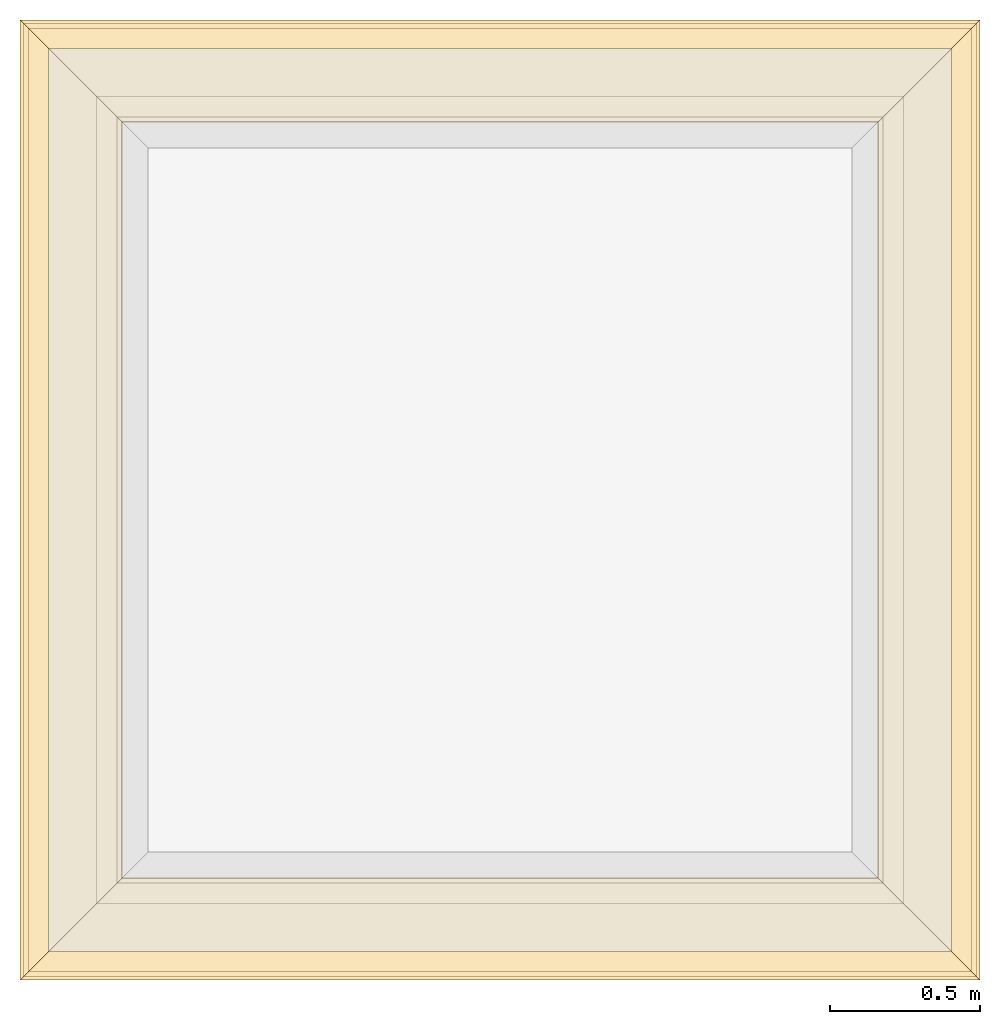
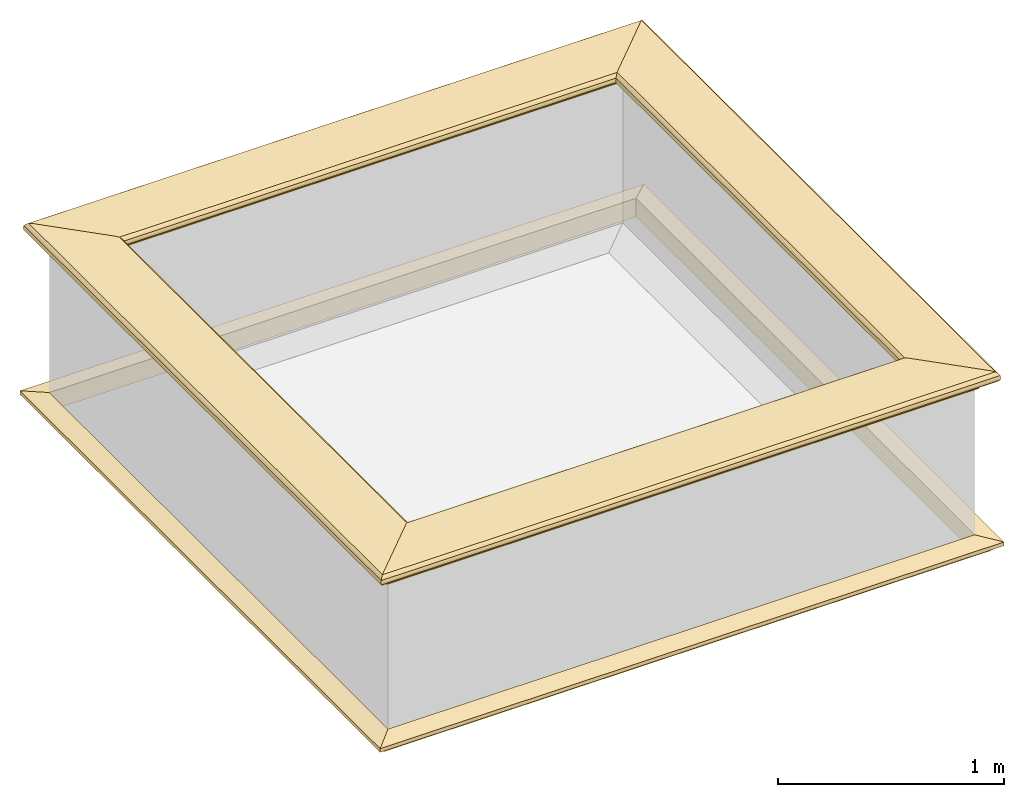
# One storey, part 2 of 2: 8 coverings, 2 elements without a shape of their own.
"""IFC4 building model written with IfcOpenShell, lengths in metres."""

from ifc_helpers import new_model, si_unit, frame, origin_with_axes, origin_2d_with_axis, place, context, subcontext, project, library, spatial, polyline, outline, extrude, clip, halfspace, material, material_profile, profile_set, profile_usage, type_object, element, aggregate, save


model = new_model("IFC4")

# Units and contexts
model_context = context("Model", 3, precision=1e-05, world=origin_with_axes())
plan_context = context("Plan", 2, precision=1e-05, world=origin_2d_with_axis())
body_context = subcontext(model_context, "Body", "Model", "MODEL_VIEW")
ifc_project = project(units=[si_unit("LENGTHUNIT", "METRE"), si_unit("AREAUNIT", "SQUARE_METRE"), si_unit("VOLUMEUNIT", "CUBIC_METRE"), si_unit("PLANEANGLEUNIT", "RADIAN")], contexts=[model_context, plan_context])
project_library = library(declared=ifc_project)

# Site, building, storey
site = spatial("IfcSite", under=ifc_project)
building = spatial("IfcBuilding", under=site, Name="Cube")
storey_placement = place(None, frame((0.0, 0.0, 2.5), z_axis=(0.0, 0.0, 1.0), x_axis=(1.0, 0.0, 0.0)))
storey = spatial("IfcBuildingStorey", under=building, at=storey_placement, Name="1", CompositionType="ELEMENT", Elevation=2.5)

# Assembly, coverings
assembly_1_placement = place(storey_placement, frame((0.0, 0.0, -2.5), z_axis=(0.0, 0.0, 1.0), x_axis=(1.0, 0.0, 0.0)))
assembly_1 = element("IfcElementAssembly", 1, at=assembly_1_placement, inside=storey, Name="coping")
ifc_material = material(Name="Masonry")
ifc_material_profile_1 = material_profile(ifc_material, outline(polyline([(0.265, 0.795), (0.268, 0.807), (0.274, 0.816), (0.283, 0.822), (0.295, 0.825), (0.295, 0.84), (0.305, 0.84), (0.317, 0.842), (0.326, 0.849), (0.333, 0.858), (0.335, 0.87), (0.333, 0.882), (0.326, 0.891), (0.317, 0.898), (0.305, 0.9), (0.035, 0.9), (0.023, 0.898), (0.014, 0.891), (0.007, 0.882), (0.005, 0.87), (0.007, 0.858), (0.014, 0.849), (0.023, 0.842), (0.035, 0.84), (0.045, 0.84), (0.045, 0.825), (0.057, 0.822), (0.066, 0.816), (0.072, 0.807), (0.075, 0.795), (0.265, 0.795)])))
ifc_profile_set_1 = profile_set([ifc_material_profile_1])
ifc_profile_usage_1 = profile_usage(ifc_profile_set_1)
covering_type_1 = type_object("IfcCoveringType", Name="coping", PredefinedType="NOTDEFINED", material=ifc_profile_set_1)
covering_1_placement = place(assembly_1_placement, frame((-1.0, 2.5, 2.5), z_axis=(1.0, 0.0, 0.0), x_axis=(0.0, 1.0, 0.0)))
covering_1 = element("IfcCovering", 2, at=covering_1_placement, type_object=covering_type_1, material=ifc_profile_usage_1, Name="coping", context=body_context, shape_type="Clipping", body=[
    clip(clip(extrude(outline(polyline([(0.265, 0.795), (0.268, 0.807), (0.274, 0.816), (0.283, 0.822), (0.295, 0.825), (0.295, 0.84), (0.305, 0.84), (0.317, 0.842), (0.326, 0.849), (0.333, 0.858), (0.335, 0.87), (0.333, 0.882), (0.326, 0.891), (0.317, 0.898), (0.305, 0.9), (0.035, 0.9), (0.023, 0.898), (0.014, 0.891), (0.007, 0.882), (0.005, 0.87), (0.007, 0.858), (0.014, 0.849), (0.023, 0.842), (0.035, 0.84), (0.045, 0.84), (0.045, 0.825), (0.057, 0.822), (0.066, 0.816), (0.072, 0.807), (0.075, 0.795), (0.265, 0.795)])), origin_with_axes(), (0.0, 0.0, 1.0), 4.5), halfspace(frame((0.0, -2.5, 1.0), z_axis=(-0.707106781186547, 0.0, -0.707106781186547), x_axis=(0.707106781186547, 0.0, -0.707106781186547)), False)), halfspace(frame((0.0, -2.5, 3.5), z_axis=(-0.707106781186547, 0.0, 0.707106781186547), x_axis=(0.707106781186547, 0.0, 0.707106781186547)), False)),
])
ifc_profile_usage_2 = profile_usage(ifc_profile_set_1)
covering_2_placement = place(assembly_1_placement, frame((0.0, -1.0, 2.5), z_axis=(0.0, 1.0, 0.0), x_axis=(-1.0, 0.0, 0.0)))
covering_2 = element("IfcCovering", 3, at=covering_2_placement, type_object=covering_type_1, material=ifc_profile_usage_2, Name="coping", context=body_context, shape_type="Clipping", body=[
    clip(clip(extrude(outline(polyline([(0.265, 0.795), (0.268, 0.807), (0.274, 0.816), (0.283, 0.822), (0.295, 0.825), (0.295, 0.84), (0.305, 0.84), (0.317, 0.842), (0.326, 0.849), (0.333, 0.858), (0.335, 0.87), (0.333, 0.882), (0.326, 0.891), (0.317, 0.898), (0.305, 0.9), (0.035, 0.9), (0.023, 0.898), (0.014, 0.891), (0.007, 0.882), (0.005, 0.87), (0.007, 0.858), (0.014, 0.849), (0.023, 0.842), (0.035, 0.84), (0.045, 0.84), (0.045, 0.825), (0.057, 0.822), (0.066, 0.816), (0.072, 0.807), (0.075, 0.795), (0.265, 0.795)])), origin_with_axes(), (0.0, 0.0, 1.0), 4.5), halfspace(frame((0.0, -2.5, 1.0), z_axis=(-0.707106781186547, 0.0, -0.707106781186547), x_axis=(0.707106781186547, 0.0, -0.707106781186547)), False)), halfspace(frame((0.0, -2.5, 3.5), z_axis=(-0.707106781186547, 0.0, 0.707106781186547), x_axis=(0.707106781186547, 0.0, 0.707106781186547)), False)),
])
ifc_profile_usage_3 = profile_usage(ifc_profile_set_1)
covering_3_placement = place(assembly_1_placement, frame((3.5, 0.0, 2.5), z_axis=(-1.0, 0.0, 0.0), x_axis=(0.0, -1.0, 0.0)))
covering_3 = element("IfcCovering", 4, at=covering_3_placement, type_object=covering_type_1, material=ifc_profile_usage_3, Name="coping", context=body_context, shape_type="Clipping", body=[
    clip(clip(extrude(outline(polyline([(0.265, 0.795), (0.268, 0.807), (0.274, 0.816), (0.283, 0.822), (0.295, 0.825), (0.295, 0.84), (0.305, 0.84), (0.317, 0.842), (0.326, 0.849), (0.333, 0.858), (0.335, 0.87), (0.333, 0.882), (0.326, 0.891), (0.317, 0.898), (0.305, 0.9), (0.035, 0.9), (0.023, 0.898), (0.014, 0.891), (0.007, 0.882), (0.005, 0.87), (0.007, 0.858), (0.014, 0.849), (0.023, 0.842), (0.035, 0.84), (0.045, 0.84), (0.045, 0.825), (0.057, 0.822), (0.066, 0.816), (0.072, 0.807), (0.075, 0.795), (0.265, 0.795)])), origin_with_axes(), (0.0, 0.0, 1.0), 4.5), halfspace(frame((0.0, -2.5, 1.0), z_axis=(-0.707106781186547, 0.0, -0.707106781186547), x_axis=(0.707106781186547, 0.0, -0.707106781186547)), False)), halfspace(frame((0.0, -2.5, 3.5), z_axis=(-0.707106781186547, 0.0, 0.707106781186547), x_axis=(0.707106781186547, 0.0, 0.707106781186547)), False)),
])
ifc_profile_usage_4 = profile_usage(ifc_profile_set_1)
covering_4_placement = place(assembly_1_placement, frame((2.5, 3.5, 2.5), z_axis=(0.0, -1.0, 0.0), x_axis=(1.0, 0.0, 0.0)))
covering_4 = element("IfcCovering", 5, at=covering_4_placement, type_object=covering_type_1, material=ifc_profile_usage_4, Name="coping", context=body_context, shape_type="Clipping", body=[
    clip(clip(extrude(outline(polyline([(0.265, 0.795), (0.268, 0.807), (0.274, 0.816), (0.283, 0.822), (0.295, 0.825), (0.295, 0.84), (0.305, 0.84), (0.317, 0.842), (0.326, 0.849), (0.333, 0.858), (0.335, 0.87), (0.333, 0.882), (0.326, 0.891), (0.317, 0.898), (0.305, 0.9), (0.035, 0.9), (0.023, 0.898), (0.014, 0.891), (0.007, 0.882), (0.005, 0.87), (0.007, 0.858), (0.014, 0.849), (0.023, 0.842), (0.035, 0.84), (0.045, 0.84), (0.045, 0.825), (0.057, 0.822), (0.066, 0.816), (0.072, 0.807), (0.075, 0.795), (0.265, 0.795)])), origin_with_axes(), (0.0, 0.0, 1.0), 4.5), halfspace(frame((0.0, -2.5, 1.0), z_axis=(-0.707106781186547, 0.0, -0.707106781186547), x_axis=(0.707106781186547, 0.0, -0.707106781186547)), False)), halfspace(frame((0.0, -2.5, 3.5), z_axis=(-0.707106781186547, 0.0, 0.707106781186547), x_axis=(0.707106781186547, 0.0, 0.707106781186547)), False)),
])
aggregate(assembly_1, [covering_1, covering_2, covering_3, covering_4])

assembly_2_placement = place(storey_placement, frame((0.0, 0.0, -2.5), z_axis=(0.0, 0.0, 1.0), x_axis=(1.0, 0.0, 0.0)))
assembly_2 = element("IfcElementAssembly", 6, at=assembly_2_placement, inside=storey, Name="crown")
ifc_material_profile_2 = material_profile(ifc_material, outline(polyline([(0.25, -0.1), (0.265, -0.1), (0.265, -0.085), (0.278, -0.084), (0.289, -0.081), (0.301, -0.074), (0.309, -0.065), (0.315, -0.055), (0.324, -0.044), (0.334, -0.038), (0.345, -0.035), (0.345, -0.015), (0.25, 0.0), (0.25, -0.1)])))
ifc_profile_set_2 = profile_set([ifc_material_profile_2])
ifc_profile_usage_5 = profile_usage(ifc_profile_set_2)
covering_type_2 = type_object("IfcCoveringType", Name="crown", PredefinedType="NOTDEFINED", material=ifc_profile_set_2)
covering_5_placement = place(assembly_2_placement, frame((-1.0, 2.5, 2.5), z_axis=(1.0, 0.0, 0.0), x_axis=(0.0, 1.0, 0.0)))
covering_5 = element("IfcCovering", 7, at=covering_5_placement, type_object=covering_type_2, material=ifc_profile_usage_5, Name="crown", context=body_context, shape_type="Clipping", body=[
    clip(clip(extrude(outline(polyline([(0.25, -0.1), (0.265, -0.1), (0.265, -0.085), (0.278, -0.084), (0.289, -0.081), (0.301, -0.074), (0.309, -0.065), (0.315, -0.055), (0.324, -0.044), (0.334, -0.038), (0.345, -0.035), (0.345, -0.015), (0.25, 0.0), (0.25, -0.1)])), origin_with_axes(), (0.0, 0.0, 1.0), 4.5), halfspace(frame((0.0, -2.5, 1.0), z_axis=(-0.707106781186547, 0.0, -0.707106781186547), x_axis=(0.707106781186547, 0.0, -0.707106781186547)), False)), halfspace(frame((0.0, -2.5, 3.5), z_axis=(-0.707106781186547, 0.0, 0.707106781186547), x_axis=(0.707106781186547, 0.0, 0.707106781186547)), False)),
])
ifc_profile_usage_6 = profile_usage(ifc_profile_set_2)
covering_6_placement = place(assembly_2_placement, frame((0.0, -1.0, 2.5), z_axis=(0.0, 1.0, 0.0), x_axis=(-1.0, 0.0, 0.0)))
covering_6 = element("IfcCovering", 8, at=covering_6_placement, type_object=covering_type_2, material=ifc_profile_usage_6, Name="crown", context=body_context, shape_type="Clipping", body=[
    clip(clip(extrude(outline(polyline([(0.25, -0.1), (0.265, -0.1), (0.265, -0.085), (0.278, -0.084), (0.289, -0.081), (0.301, -0.074), (0.309, -0.065), (0.315, -0.055), (0.324, -0.044), (0.334, -0.038), (0.345, -0.035), (0.345, -0.015), (0.25, 0.0), (0.25, -0.1)])), origin_with_axes(), (0.0, 0.0, 1.0), 4.5), halfspace(frame((0.0, -2.5, 1.0), z_axis=(-0.707106781186547, 0.0, -0.707106781186547), x_axis=(0.707106781186547, 0.0, -0.707106781186547)), False)), halfspace(frame((0.0, -2.5, 3.5), z_axis=(-0.707106781186547, 0.0, 0.707106781186547), x_axis=(0.707106781186547, 0.0, 0.707106781186547)), False)),
])
ifc_profile_usage_7 = profile_usage(ifc_profile_set_2)
covering_7_placement = place(assembly_2_placement, frame((3.5, 0.0, 2.5), z_axis=(-1.0, 0.0, 0.0), x_axis=(0.0, -1.0, 0.0)))
covering_7 = element("IfcCovering", 9, at=covering_7_placement, type_object=covering_type_2, material=ifc_profile_usage_7, Name="crown", context=body_context, shape_type="Clipping", body=[
    clip(clip(extrude(outline(polyline([(0.25, -0.1), (0.265, -0.1), (0.265, -0.085), (0.278, -0.084), (0.289, -0.081), (0.301, -0.074), (0.309, -0.065), (0.315, -0.055), (0.324, -0.044), (0.334, -0.038), (0.345, -0.035), (0.345, -0.015), (0.25, 0.0), (0.25, -0.1)])), origin_with_axes(), (0.0, 0.0, 1.0), 4.5), halfspace(frame((0.0, -2.5, 1.0), z_axis=(-0.707106781186547, 0.0, -0.707106781186547), x_axis=(0.707106781186547, 0.0, -0.707106781186547)), False)), halfspace(frame((0.0, -2.5, 3.5), z_axis=(-0.707106781186547, 0.0, 0.707106781186547), x_axis=(0.707106781186547, 0.0, 0.707106781186547)), False)),
])
ifc_profile_usage_8 = profile_usage(ifc_profile_set_2)
covering_8_placement = place(assembly_2_placement, frame((2.5, 3.5, 2.5), z_axis=(0.0, -1.0, 0.0), x_axis=(1.0, 0.0, 0.0)))
covering_8 = element("IfcCovering", 10, at=covering_8_placement, type_object=covering_type_2, material=ifc_profile_usage_8, Name="crown", context=body_context, shape_type="Clipping", body=[
    clip(clip(extrude(outline(polyline([(0.25, -0.1), (0.265, -0.1), (0.265, -0.085), (0.278, -0.084), (0.289, -0.081), (0.301, -0.074), (0.309, -0.065), (0.315, -0.055), (0.324, -0.044), (0.334, -0.038), (0.345, -0.035), (0.345, -0.015), (0.25, 0.0), (0.25, -0.1)])), origin_with_axes(), (0.0, 0.0, 1.0), 4.5), halfspace(frame((0.0, -2.5, 1.0), z_axis=(-0.707106781186547, 0.0, -0.707106781186547), x_axis=(0.707106781186547, 0.0, -0.707106781186547)), False)), halfspace(frame((0.0, -2.5, 3.5), z_axis=(-0.707106781186547, 0.0, 0.707106781186547), x_axis=(0.707106781186547, 0.0, 0.707106781186547)), False)),
])
aggregate(assembly_2, [covering_5, covering_6, covering_7, covering_8])

save(model, "model.ifc")
